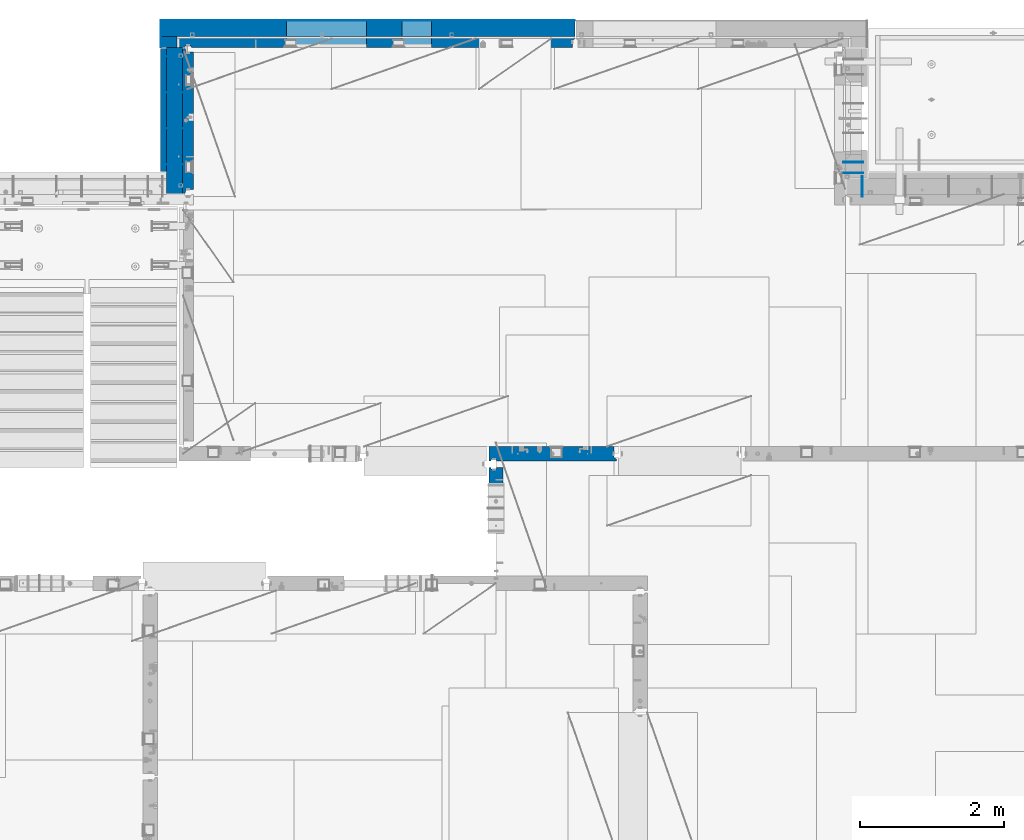
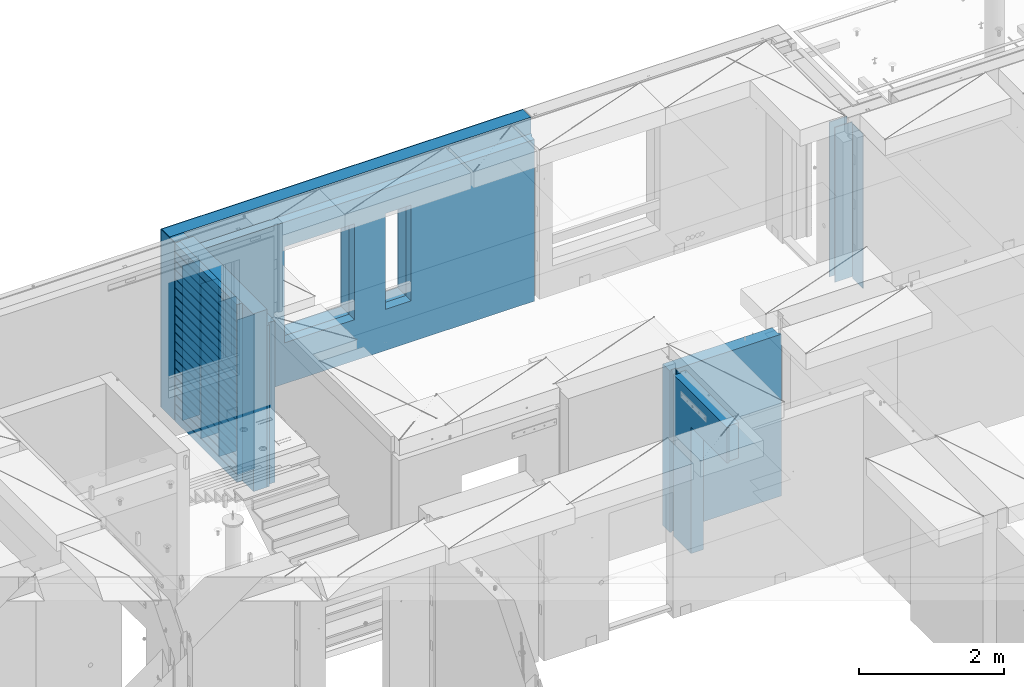
# One storey, part 231 of 341: 17 walls, 6 elements without a shape of their own.
"""IFC2X3 building model written with IfcOpenShell, lengths in millimetres."""

from ifc_helpers import new_model, si_unit, frame, origin_with_axes, place, context, subcontext, project, spatial, faceted_brep, material, type_object, element, aggregate, save


model = new_model("IFC2X3")

# Units and contexts
model_context = context("Model", 3, precision=1e-05, world=origin_with_axes())
body_context = subcontext(model_context, "Body", "Model", "MODEL_VIEW")
ifc_project = project(units=[si_unit("LENGTHUNIT", "METRE", prefix="MILLI"), si_unit("AREAUNIT", "SQUARE_METRE"), si_unit("VOLUMEUNIT", "CUBIC_METRE"), si_unit("MASSUNIT", "GRAM", prefix="KILO"), si_unit("TIMEUNIT", "SECOND"), si_unit("PLANEANGLEUNIT", "RADIAN"), si_unit("SOLIDANGLEUNIT", "STERADIAN"), si_unit("THERMODYNAMICTEMPERATUREUNIT", "DEGREE_CELSIUS"), si_unit("LUMINOUSINTENSITYUNIT", "LUMEN")], contexts=[model_context])

# Site, building, storey
site_placement = place(None, origin_with_axes())
site = spatial("IfcSite", under=ifc_project, at=site_placement, CompositionType="ELEMENT")
building_placement = place(site_placement, origin_with_axes())
building = spatial("IfcBuilding", under=site, at=building_placement, CompositionType="ELEMENT")
storey_placement = place(building_placement, origin_with_axes())
storey = spatial("IfcBuildingStorey", under=building, at=storey_placement, Name="5", CompositionType="ELEMENT", Elevation=0.0)

# Assembly, wall
assembly_1_placement = place(storey_placement, origin_with_axes())
assembly_1 = element("IfcElementAssembly", 1, at=assembly_1_placement, inside=storey, AssemblyPlace="NOTDEFINED", PredefinedType="REINFORCEMENT_UNIT")
ifc_material_1 = material(Name="Undefined")
wall_type_1 = type_object("IfcWallType", PredefinedType="NOTDEFINED")
wall_1_placement = place(assembly_1_placement, frame((31695.0, 20549.9951872276, 95115.0), z_axis=(0.0, 0.0, 1.0), x_axis=(0.0, 1.0, 0.0)))
wall_1 = element("IfcWall", 2, at=wall_1_placement, type_object=wall_type_1, material=ifc_material_1, Name="(PD)", context=body_context, shape_type="Brep", body=[
    faceted_brep([(0.0, 5.0, -1300.0), (0.0, 5.0, 1300.0), (280.0, 5.0, 1300.0), (280.0, 5.0, -1300.0), (0.0, -5.0, 1300.0), (280.0, -5.0, 1300.0), (0.0, -5.0, -1300.0), (280.0, -5.0, -1300.0)], [[[0, 1, 2, 3]], [[1, 4, 5, 2]], [[4, 6, 7, 5]], [[6, 0, 3, 7]], [[5, 7, 3, 2]], [[6, 4, 1, 0]]]),
])
aggregate(assembly_1, [wall_1])

# Assembly, walls
assembly_2_placement = place(storey_placement, origin_with_axes())
assembly_2 = element("IfcElementAssembly", 3, at=assembly_2_placement, inside=storey, AssemblyPlace="NOTDEFINED", PredefinedType="REINFORCEMENT_UNIT")
wall_2_placement = place(assembly_2_placement, frame((22290.0, 22495.0, 95110.0), z_axis=(0.0, 0.0, 1.0), x_axis=(-1.0, 3.00000001838171e-08, 0.0)))
wall_2 = element("IfcWall", 4, at=wall_2_placement, type_object=wall_type_1, material=ifc_material_1, Name="(PD)", context=body_context, shape_type="Brep", body=[
    faceted_brep([(0.0, 5.0, -1300.0), (0.0, 5.0, 1300.0), (280.0, 5.0, 1300.0), (280.0, 5.0, -1300.0), (0.0, -5.0, 1300.0), (280.0, -5.0, 1300.0), (0.0, -5.0, -1300.0), (280.0, -5.0, -1300.0)], [[[0, 1, 2, 3]], [[1, 4, 5, 2]], [[4, 6, 7, 5]], [[6, 0, 3, 7]], [[5, 7, 3, 2]], [[6, 4, 1, 0]]]),
])
wall_3_placement = place(assembly_2_placement, frame((22290.0, 21995.0, 95110.0), z_axis=(0.0, 0.0, 1.0), x_axis=(-1.0, 3.00000001838171e-08, 0.0)))
wall_3 = element("IfcWall", 5, at=wall_3_placement, type_object=wall_type_1, material=ifc_material_1, Name="(PD)", context=body_context, shape_type="Brep", body=[
    faceted_brep([(0.0, 5.0, -1300.0), (0.0, 5.0, 1300.0), (280.0, 5.0, 1300.0), (280.0, 5.0, -1300.0), (0.0, -5.0, 1300.0), (280.0, -5.0, 1300.0), (0.0, -5.0, -1300.0), (280.0, -5.0, -1300.0)], [[[0, 1, 2, 3]], [[1, 4, 5, 2]], [[4, 6, 7, 5]], [[6, 0, 3, 7]], [[5, 7, 3, 2]], [[6, 4, 1, 0]]]),
])
wall_4_placement = place(assembly_2_placement, frame((22290.0, 21495.0, 95110.0), z_axis=(0.0, 0.0, 1.0), x_axis=(-1.0, 3.00000001838171e-08, 0.0)))
wall_4 = element("IfcWall", 6, at=wall_4_placement, type_object=wall_type_1, material=ifc_material_1, Name="(PD)", context=body_context, shape_type="Brep", body=[
    faceted_brep([(0.0, 5.0, -1300.0), (0.0, 5.0, 1300.0), (280.0, 5.0, 1300.0), (280.0, 5.0, -1300.0), (0.0, -5.0, 1300.0), (280.0, -5.0, 1300.0), (0.0, -5.0, -1300.0), (280.0, -5.0, -1300.0)], [[[0, 1, 2, 3]], [[1, 4, 5, 2]], [[4, 6, 7, 5]], [[6, 0, 3, 7]], [[5, 7, 3, 2]], [[6, 4, 1, 0]]]),
])

assembly_3_placement = place(storey_placement, origin_with_axes())
assembly_3 = element("IfcElementAssembly", 7, at=assembly_3_placement, inside=storey, AssemblyPlace="NOTDEFINED", PredefinedType="REINFORCEMENT_UNIT")
wall_5_placement = place(assembly_3_placement, frame((31429.9951872276, 20875.0, 95115.0), z_axis=(0.0, 0.0, 1.0), x_axis=(1.0, 0.0, 0.0)))
wall_5 = element("IfcWall", 8, at=wall_5_placement, type_object=wall_type_1, material=ifc_material_1, Name="(PD)", context=body_context, shape_type="Brep", body=[
    faceted_brep([(0.0, 5.0, -1300.0), (0.0, 5.0, 1300.0), (280.0, 5.0, 1300.0), (280.0, 5.0, -1300.0), (0.0, -5.0, 1300.0), (280.0, -5.0, 1300.0), (0.0, -5.0, -1300.0), (280.0, -5.0, -1300.0)], [[[0, 1, 2, 3]], [[1, 4, 5, 2]], [[4, 6, 7, 5]], [[6, 0, 3, 7]], [[5, 7, 3, 2]], [[6, 4, 1, 0]]]),
])
wall_6_placement = place(assembly_3_placement, frame((31429.9951872276, 21025.0, 95115.0), z_axis=(0.0, 0.0, 1.0), x_axis=(1.0, 0.0, 0.0)))
wall_6 = element("IfcWall", 9, at=wall_6_placement, type_object=wall_type_1, material=ifc_material_1, Name="(PD)", context=body_context, shape_type="Brep", body=[
    faceted_brep([(0.0, 5.0, -1300.0), (0.0, 5.0, 1300.0), (280.0, 5.0, 1300.0), (280.0, 5.0, -1300.0), (0.0, -5.0, 1300.0), (280.0, -5.0, 1300.0), (0.0, -5.0, -1300.0), (280.0, -5.0, -1300.0)], [[[0, 1, 2, 3]], [[1, 4, 5, 2]], [[4, 6, 7, 5]], [[6, 0, 3, 7]], [[5, 7, 3, 2]], [[6, 4, 1, 0]]]),
])
aggregate(assembly_3, [wall_5, wall_6])

# Wall
wall_7_placement = place(assembly_2_placement, frame((22290.0, 20995.0, 95110.0), z_axis=(0.0, 0.0, 1.0), x_axis=(-1.0, 3.00000001838171e-08, 0.0)))
wall_7 = element("IfcWall", 10, at=wall_7_placement, type_object=wall_type_1, material=ifc_material_1, Name="(PD)", context=body_context, shape_type="Brep", body=[
    faceted_brep([(0.0, 5.0, -1300.0), (0.0, 5.0, 1300.0), (280.0, 5.0, 1300.0), (280.0, 5.0, -1300.0), (0.0, -5.0, 1300.0), (280.0, -5.0, 1300.0), (0.0, -5.0, -1300.0), (280.0, -5.0, -1300.0)], [[[0, 1, 2, 3]], [[1, 4, 5, 2]], [[4, 6, 7, 5]], [[6, 0, 3, 7]], [[5, 7, 3, 2]], [[6, 4, 1, 0]]]),
])

# Assembly, wall
assembly_4_placement = place(storey_placement, origin_with_axes())
assembly_4 = element("IfcElementAssembly", 11, at=assembly_4_placement, inside=storey, AssemblyPlace="NOTDEFINED", PredefinedType="REINFORCEMENT_UNIT")
ifc_material_2 = material(Name="CONCRETE/C25/30")
wall_type_2 = type_object("IfcWallType", PredefinedType="NOTDEFINED")
wall_8_placement = place(assembly_4_placement, frame((26510.0014364077, 16980.0, 95112.5), z_axis=(0.0, 0.0, 1.0), x_axis=(1.0, 0.0, 0.0)))
wall_8 = element("IfcWall", 12, at=wall_8_placement, type_object=wall_type_2, material=ifc_material_2, context=body_context, shape_type="Brep", body=[
    faceted_brep([(1739.99847412109, 100.0, 1357.5), (1739.99847412109, -57.0, 1357.5), (1739.99847412109, -57.0, -1357.5), (1739.99847412109, 100.0, -1357.5), (1769.99847412109, -70.0, 1357.5), (1769.99847412109, -70.0, -1357.5), (0.0, -100.0, -1357.5), (0.0, -100.0, 1357.5), (0.0, 100.0, 1357.5), (0.0, 100.0, -1357.5), (29.998563592264, -100.0, -1357.5), (29.998563592264, -100.0, 1357.5), (29.998563592264, -80.0008544921875, -1357.5), (29.998563592264, -80.0008544921875, 1357.5), (109.998563592264, -80.0008544921875, -1357.5), (109.998563592264, -80.0008544921875, 1357.5), (109.998563592264, -100.0, -1357.5), (109.998563592264, -100.0, 1357.5), (1769.99847412109, -100.0, -1357.5), (1769.99847412109, -100.0, 1357.5)], [[[0, 1, 2, 3]], [[4, 5, 2, 1]], [[6, 7, 8, 9]], [[7, 6, 10, 11]], [[11, 10, 12, 13]], [[13, 12, 14, 15]], [[15, 14, 16, 17]], [[18, 19, 17, 16]], [[0, 8, 7, 11, 13, 15, 17, 19, 4, 1]], [[9, 8, 0, 3]], [[18, 16, 14, 12, 10, 6, 9, 3, 2, 5]], [[19, 18, 5, 4]]]),
])
aggregate(assembly_4, [wall_8])

assembly_5_placement = place(storey_placement, origin_with_axes())
assembly_5 = element("IfcElementAssembly", 13, at=assembly_5_placement, inside=storey, AssemblyPlace="NOTDEFINED", PredefinedType="REINFORCEMENT_UNIT")
wall_9_placement = place(assembly_5_placement, frame((26609.9991475894, 15280.0004107749, 95112.5), z_axis=(0.0, 0.0, 1.0), x_axis=(0.0, 1.0, 0.0)))
wall_9 = element("IfcWall", 14, at=wall_9_placement, type_object=wall_type_2, material=ifc_material_2, context=body_context, shape_type="Brep", body=[
    faceted_brep([(1509.99949975397, 70.0, 1357.5), (1489.99949975397, 70.0, 1357.5), (1489.99949975397, 70.0, -1357.5), (1509.99949975397, 70.0, -1357.5), (1489.99949975397, -10.0, 1357.5), (1489.99949975397, -10.0, -1357.5), (1509.99949975397, -10.0, 1357.5), (1509.99949975397, -10.0, -1357.5), (29.9995892251427, 70.0, 1357.5), (29.9995892251427, 70.0, 762.5), (59.9995892251427, 57.0, 762.5), (59.9995892251427, 57.0, 1357.5), (29.9995892251427, 100.0, 1357.5), (29.9995892251427, 100.0, 762.5), (1509.99949975397, 100.0, 1357.5), (1509.99949975397, 100.0, -1357.5), (1019.99979369292, 100.0, -1357.5), (1019.99979369292, 100.0, 762.5), (1019.99979369292, -100.0, 762.5), (1019.99979369292, -100.0, -1357.5), (59.9995892251427, -100.0, 762.5), (59.9995892251427, -100.0, 1357.5), (1509.99949975397, -100.0, -1357.5), (1509.99949975397, -100.0, 1357.5)], [[[0, 1, 2, 3]], [[4, 5, 2, 1]], [[6, 7, 5, 4]], [[8, 9, 10, 11]], [[12, 13, 9, 8]], [[12, 14, 15, 16, 17, 13]], [[18, 17, 16, 19]], [[9, 13, 17, 18, 20, 10]], [[21, 11, 10, 20]], [[18, 19, 22, 23, 21, 20]], [[1, 0, 14, 12, 8, 11, 21, 23, 6, 4]], [[15, 14, 0, 3]], [[22, 19, 16, 15, 3, 2, 5, 7]], [[23, 22, 7, 6]]]),
])
aggregate(assembly_5, [wall_9])

# Wall
ifc_material_3 = material(Name="COS5gt")
wall_type_3 = type_object("IfcWallType", PredefinedType="NOTDEFINED")
wall_10_placement = place(assembly_2_placement, frame((22150.0, 20595.0, 95247.5), z_axis=(0.0, 0.0, 1.0), x_axis=(0.0, 1.0, 0.0)))
wall_10 = element("IfcWall", 15, at=wall_10_placement, type_object=wall_type_3, material=ifc_material_3, context=body_context, shape_type="Brep", body=[
    faceted_brep([(0.0, 110.0, -1492.5), (0.0, 110.0, 1492.5), (2025.0, 110.0, 1492.5), (2025.0, 110.0, -1492.5), (0.0, -110.0, 1492.5), (2025.0, -110.0, 1492.5), (0.0, -110.0, -1492.5), (2025.0, -110.0, -1492.5)], [[[0, 1, 2, 3]], [[1, 4, 5, 2]], [[4, 6, 7, 5]], [[6, 0, 3, 7]], [[5, 7, 3, 2]], [[6, 4, 1, 0]]]),
])

# Assembly, walls
assembly_6_placement = place(storey_placement, origin_with_axes())
assembly_6 = element("IfcElementAssembly", 16, at=assembly_6_placement, inside=storey, AssemblyPlace="NOTDEFINED", PredefinedType="REINFORCEMENT_UNIT")
ifc_material_4 = material()
wall_11_placement = place(assembly_6_placement, frame((22075.0, 22620.0, 95247.5), z_axis=(0.0, 0.0, 1.0), x_axis=(0.0, 1.0, 0.0)))
wall_11 = element("IfcWall", 17, at=wall_11_placement, type_object=wall_type_3, material=ifc_material_4, context=body_context, shape_type="Brep", body=[
    faceted_brep([(0.0, 110.0, -1492.5), (0.0, 110.0, 1492.5), (150.0, 110.0, 1492.5), (150.0, 110.0, -1492.5), (0.0, -110.0, 1492.5), (150.0, -110.0, 1492.5), (0.0, -110.0, -1492.5), (150.0, -110.0, -1492.5)], [[[0, 1, 2, 3]], [[1, 4, 5, 2]], [[4, 6, 7, 5]], [[6, 0, 3, 7]], [[5, 7, 3, 2]], [[6, 4, 1, 0]]]),
])
wall_12_placement = place(assembly_6_placement, frame((22260.0, 22880.0, 95247.5), z_axis=(0.0, 0.0, 1.0), x_axis=(1.0, 0.0, 0.0)))
wall_12 = element("IfcWall", 18, at=wall_12_placement, type_object=wall_type_3, material=ifc_material_4, context=body_context, shape_type="Brep", body=[
    faceted_brep([(-295.0, 110.0, 1492.5), (-295.0, -110.0, 1492.5), (5445.0, -110.0, 1492.5), (5445.0, 110.0, 1492.5), (-295.0, -110.0, -1492.5), (-295.0, 110.0, -1492.5), (5445.0, 110.0, -1492.5), (5445.0, -110.0, -1492.5), (3044.99635379813, 110.0, -802.5), (3454.99635379813, 110.0, -802.5), (3454.99635379813, 110.0, 807.5), (3044.99635379813, 110.0, 807.5), (1444.99910133321, 110.0, -802.5), (2554.99910133321, 110.0, -802.5), (2554.99910133321, 110.0, 807.5), (1444.99910133321, 110.0, 807.5), (1444.99910133321, -110.0, -802.5), (2554.99910133321, -110.0, -802.5), (1444.99910133321, -110.0, 807.5), (2554.99910133321, -110.0, 807.5), (3044.99635379813, -110.0, -802.5), (3044.99635379813, -110.0, 807.5), (3454.99635379813, -110.0, 807.5), (3454.99635379813, -110.0, -802.5)], [[[0, 1, 2, 3]], [[4, 1, 0, 5]], [[4, 5, 6, 7]], [[2, 7, 6, 3]], [[5, 0, 3, 6], [8, 9, 10, 11], [12, 13, 14, 15]], [[12, 16, 17, 13]], [[15, 18, 16, 12]], [[14, 19, 18, 15]], [[13, 17, 19, 14]], [[1, 4, 7, 2], [20, 21, 22, 23], [16, 18, 19, 17]], [[10, 22, 21, 11]], [[9, 23, 22, 10]], [[8, 20, 23, 9]], [[11, 21, 20, 8]]]),
])

# Wall
ifc_material_5 = material(Name="CONCRETE/C30/37")
wall_type_4 = type_object("IfcWallType", PredefinedType="NOTDEFINED")
wall_13_placement = place(assembly_2_placement, frame((21997.5, 20900.0, 95247.5), z_axis=(0.0, 0.0, 1.0), x_axis=(0.0, 1.0, 0.0)))
wall_13 = element("IfcWall", 19, at=wall_13_placement, type_object=wall_type_4, material=ifc_material_5, context=body_context, shape_type="Brep", body=[
    faceted_brep([(1705.0, 42.5, -1357.0), (0.0, 42.5, -1357.00000005524), (0.0, 32.4999992507037, -1355.00000000074), (1705.0, 32.5, -1355.0), (1705.0, 32.5, -1345.0), (0.0, 32.4999991127006, -1344.99999959956), (0.0, 42.5, -1343.00000011075), (1705.0, 42.5, -1343.0), (0.0, -42.5, -1492.5), (0.0, 42.5, -1492.5), (1705.0, 42.5, -1492.5), (1705.0, -42.5, -1492.5), (0.0, -42.5, 1492.5), (1705.0, -42.5, 1492.5), (0.0, 42.5, 1492.5), (1705.0, 42.5, 1492.5), (1705.0, 42.5, 1357.0), (0.0, 42.5, 1356.99999988925), (1705.0, 32.5, 1355.0), (-3.63797880709171e-12, 32.4999991127006, 1355.00000040044), (1705.0, 32.5, 1345.0), (-3.63797880709171e-12, 32.4999992507037, 1344.99999999926), (1705.0, 42.5, 1343.0), (0.0, 42.5, 1342.99999994476), (1705.0, 42.5, 1207.0), (0.0, 42.5, 1206.99999988925), (1705.0, 32.5, 1205.0), (0.0, 32.4999991127006, 1205.00000040044), (1705.0, 32.5, 1195.0), (0.0, 32.4999992507037, 1194.99999999926), (1705.0, 42.5, 1193.0), (0.0, 42.5, 1192.99999994476), (1705.0, 42.5, 1057.0), (0.0, 42.5, 1056.99999988925), (1705.0, 32.5, 1055.0), (0.0, 32.4999991127006, 1055.00000040044), (1705.0, 32.5, 1045.0), (0.0, 32.4999992507037, 1044.99999999926), (1705.0, 42.5, 1043.0), (0.0, 42.5, 1042.99999994476), (1705.0, 42.5, 907.0), (0.0, 42.5, 906.999999889245), (1705.0, 32.5, 905.0), (0.0, 32.4999991127006, 905.00000040044), (1705.0, 32.5, 895.0), (0.0, 32.4999992507037, 894.999999999258), (1705.0, 42.5, 893.0), (0.0, 42.5, 892.999999944761), (1705.0, 42.5, 757.0), (0.0, 42.5, 756.999999889245), (1705.0, 32.5, 755.0), (0.0, 32.4999991127006, 755.00000040044), (1705.0, 32.5, 745.0), (0.0, 32.4999992507037, 744.999999999258), (1705.0, 42.5, 743.0), (0.0, 42.5, 742.999999944761), (1705.0, 42.5, 607.0), (0.0, 42.5, 606.999999889245), (1705.0, 32.5, 605.0), (3.63797880709171e-12, 32.4999991127006, 605.00000040044), (1705.0, 32.5, 595.0), (3.63797880709171e-12, 32.4999992507037, 594.999999999258), (1705.0, 42.5, 593.0), (0.0, 42.5, 592.999999944761), (1705.0, 42.5, 457.0), (0.0, 42.5, 456.999999889245), (1705.0, 32.5, 455.0), (0.0, 32.4999991127006, 455.00000040044), (1705.0, 32.5, 445.0), (0.0, 32.4999992507037, 444.999999999258), (1705.0, 42.5, 443.0), (0.0, 42.5, 442.999999944761), (1705.0, 42.5, 307.0), (0.0, 42.5, 306.999999889245), (1705.0, 32.5, 305.0), (-3.63797880709171e-12, 32.4999991127006, 305.00000040044), (1705.0, 32.5, 295.0), (-3.63797880709171e-12, 32.4999992507037, 294.999999999258), (1705.0, 42.5, 293.0), (0.0, 42.5, 292.999999944761), (1705.0, 42.5, 157.0), (0.0, 42.5, 156.999999889245), (1705.0, 32.5, 155.0), (-3.63797880709171e-12, 32.4999991127006, 155.00000040044), (1705.0, 32.5, 145.0), (-3.63797880709171e-12, 32.4999992507037, 144.999999999258), (1705.0, 42.5, 143.0), (0.0, 42.5, 142.999999944761), (1705.0, 42.5, 7.0), (0.0, 42.5, 6.99999988924537), (1705.0, 32.5, 5.0), (0.0, 32.4999991127006, 5.0000004004396), (1705.0, 32.5, -5.0), (0.0, 32.4999992507037, -5.00000000074215), (1705.0, 42.5, -7.0), (0.0, 42.5, -7.00000005523907), (1705.0, 42.5, -143.0), (0.0, 42.5, -143.000000110755), (1705.0, 32.5, -145.0), (3.63797880709171e-12, 32.4999991127006, -144.99999959956), (1705.0, 32.5, -155.0), (3.63797880709171e-12, 32.4999992507037, -155.000000000742), (1705.0, 42.5, -157.0), (0.0, 42.5, -157.000000055239), (1705.0, 42.5, -293.0), (0.0, 42.5, -293.000000110755), (1705.0, 32.5, -295.0), (0.0, 32.4999991127006, -294.99999959956), (1705.0, 32.5, -305.0), (0.0, 32.4999992507037, -305.000000000742), (1705.0, 42.5, -307.0), (0.0, 42.5, -307.000000055239), (1705.0, 42.5, -443.0), (0.0, 42.5, -443.000000110755), (1705.0, 32.5, -445.0), (0.0, 32.4999991127006, -444.99999959956), (1705.0, 32.5, -455.0), (0.0, 32.4999992507037, -455.000000000742), (1705.0, 42.5, -457.0), (0.0, 42.5, -457.000000055239), (1705.0, 42.5, -593.0), (0.0, 42.5, -593.000000110755), (1705.0, 32.5, -595.0), (3.63797880709171e-12, 32.4999991127006, -594.99999959956), (1705.0, 32.5, -605.0), (3.63797880709171e-12, 32.4999992507037, -605.000000000742), (1705.0, 42.5, -607.0), (0.0, 42.5, -607.000000055239), (1705.0, 42.5, -743.0), (0.0, 42.5, -743.000000110755), (1705.0, 32.5, -745.0), (0.0, 32.4999991127006, -744.99999959956), (1705.0, 32.5, -755.0), (0.0, 32.4999992507037, -755.000000000742), (1705.0, 42.5, -757.0), (0.0, 42.5, -757.000000055239), (1705.0, 42.5, -893.0), (0.0, 42.5, -893.000000110755), (1705.0, 32.5, -895.0), (0.0, 32.4999991127006, -894.99999959956), (1705.0, 32.5, -905.0), (0.0, 32.4999992507037, -905.000000000742), (1705.0, 42.5, -907.0), (0.0, 42.5, -907.000000055239), (1705.0, 42.5, -1043.0), (0.0, 42.5, -1043.00000011075), (1705.0, 32.5, -1045.0), (0.0, 32.4999991127006, -1044.99999959956), (1705.0, 32.5, -1055.0), (0.0, 32.4999992507037, -1055.00000000074), (1705.0, 42.5, -1057.0), (0.0, 42.5, -1057.00000005524), (1705.0, 42.5, -1193.0), (0.0, 42.5, -1193.00000011075), (1705.0, 32.5, -1195.0), (0.0, 32.4999991127006, -1194.99999959956), (1705.0, 32.5, -1205.0), (0.0, 32.4999992507037, -1205.00000000074), (1705.0, 42.5, -1207.0), (0.0, 42.5, -1207.00000005524)], [[[0, 1, 2, 3]], [[4, 5, 6, 7]], [[3, 2, 5, 4]], [[8, 9, 10, 11]], [[12, 8, 11, 13]], [[14, 12, 13, 15]], [[14, 15, 16, 17]], [[18, 19, 17, 16]], [[20, 21, 19, 18]], [[22, 23, 21, 20]], [[24, 25, 23, 22]], [[26, 27, 25, 24]], [[28, 29, 27, 26]], [[30, 31, 29, 28]], [[32, 33, 31, 30]], [[34, 35, 33, 32]], [[36, 37, 35, 34]], [[38, 39, 37, 36]], [[40, 41, 39, 38]], [[42, 43, 41, 40]], [[44, 45, 43, 42]], [[46, 47, 45, 44]], [[48, 49, 47, 46]], [[50, 51, 49, 48]], [[52, 53, 51, 50]], [[54, 55, 53, 52]], [[56, 57, 55, 54]], [[58, 59, 57, 56]], [[60, 61, 59, 58]], [[62, 63, 61, 60]], [[64, 65, 63, 62]], [[66, 67, 65, 64]], [[68, 69, 67, 66]], [[70, 71, 69, 68]], [[72, 73, 71, 70]], [[74, 75, 73, 72]], [[76, 77, 75, 74]], [[78, 79, 77, 76]], [[80, 81, 79, 78]], [[82, 83, 81, 80]], [[84, 85, 83, 82]], [[86, 87, 85, 84]], [[88, 89, 87, 86]], [[90, 91, 89, 88]], [[92, 93, 91, 90]], [[94, 95, 93, 92]], [[96, 97, 95, 94]], [[98, 99, 97, 96]], [[100, 101, 99, 98]], [[102, 103, 101, 100]], [[104, 105, 103, 102]], [[106, 107, 105, 104]], [[108, 109, 107, 106]], [[110, 111, 109, 108]], [[112, 113, 111, 110]], [[114, 115, 113, 112]], [[116, 117, 115, 114]], [[118, 119, 117, 116]], [[120, 121, 119, 118]], [[122, 123, 121, 120]], [[124, 125, 123, 122]], [[126, 127, 125, 124]], [[128, 129, 127, 126]], [[130, 131, 129, 128]], [[132, 133, 131, 130]], [[134, 135, 133, 132]], [[136, 137, 135, 134]], [[138, 139, 137, 136]], [[140, 141, 139, 138]], [[142, 143, 141, 140]], [[144, 145, 143, 142]], [[146, 147, 145, 144]], [[148, 149, 147, 146]], [[150, 151, 149, 148]], [[152, 153, 151, 150]], [[154, 155, 153, 152]], [[156, 157, 155, 154]], [[158, 159, 157, 156]], [[7, 6, 159, 158]], [[21, 23, 25, 27, 29, 31, 33, 35, 37, 39, 41, 43, 45, 47, 49, 51, 53, 55, 57, 59, 61, 63, 65, 67, 69, 71, 73, 75, 77, 79, 81, 83, 85, 87, 89, 91, 93, 95, 97, 99, 101, 103, 105, 107, 109, 111, 113, 115, 117, 119, 121, 123, 125, 127, 129, 131, 133, 135, 137, 139, 141, 143, 145, 147, 149, 151, 153, 155, 157, 159, 6, 5, 2, 1, 9, 8, 12, 14, 17, 19]], [[10, 9, 1, 0]], [[15, 13, 11, 10, 0, 3, 4, 7, 158, 156, 154, 152, 150, 148, 146, 144, 142, 140, 138, 136, 134, 132, 130, 128, 126, 124, 122, 120, 118, 116, 114, 112, 110, 108, 106, 104, 102, 100, 98, 96, 94, 92, 90, 88, 86, 84, 82, 80, 78, 76, 74, 72, 70, 68, 66, 64, 62, 60, 58, 56, 54, 52, 50, 48, 46, 44, 42, 40, 38, 36, 34, 32, 30, 28, 26, 24, 22, 20, 18, 16]]]),
])

wall_type_5 = type_object("IfcWallType", PredefinedType="NOTDEFINED")
wall_14_placement = place(assembly_6_placement, frame((22192.5, 22695.0, 95112.5), z_axis=(0.0, 0.0, 1.0), x_axis=(1.0, 0.0, 0.0)))
wall_14 = element("IfcWall", 20, at=wall_14_placement, type_object=wall_type_5, material=ifc_material_2, context=body_context, shape_type="Brep", body=[
    faceted_brep([(3112.49635379813, 75.0, 942.5), (3112.49635379813, -75.0000009061441, 942.5), (3112.49635379813, -75.0000002303786, -667.5), (3112.49635379813, 75.0, -667.5), (3522.49635379813, -75.0000001420558, -667.5), (3522.49635379813, 75.0, -667.5), (3522.49635379813, -75.0000008178213, 942.5), (3522.49635379813, 75.0, 942.5), (5482.5, -75.0, 1357.5), (5482.5, -75.0, -1357.5), (5482.5, 24.9999980926514, -1357.5), (5482.5, 24.9999980926514, 1357.5), (5512.5, 45.0, 1357.5), (5512.5, 75.0, 1357.5), (0.0, 75.0, 1357.5), (0.0, -75.0, 1357.5), (92.5, -75.0, 1357.5), (102.5, -55.0000022791319, 1357.5), (182.5, -55.0000022791319, 1357.5), (192.5, -75.0000022791319, 1357.5), (0.0, -75.0, -1357.5), (0.0, 75.0, -1357.5), (92.5, -75.0, -1357.5), (102.5, -55.0000022791319, -1357.5), (182.5, -55.0000022791319, -1357.5), (192.5, -75.0, -1357.5), (5512.5, 75.0, -1357.5), (5512.5, 45.0, -1357.5), (1512.49910133321, 75.0, -667.5), (2622.49910133321, 75.0, -667.5), (2622.49910133321, 75.0, 942.5), (1512.49910133321, 75.0, 942.5), (1512.49910133321, -75.000000575048, -667.5), (2622.49910133321, -75.000000335931, -667.5), (1512.49910133321, -75.0000012508135, 942.5), (2622.49910133321, -75.0000010116964, 942.5)], [[[0, 1, 2, 3]], [[3, 2, 4, 5]], [[5, 4, 6, 7]], [[7, 6, 1, 0]], [[8, 9, 10, 11]], [[8, 11, 12, 13, 14, 15, 16, 17, 18, 19]], [[20, 15, 14, 21]], [[15, 20, 22, 16]], [[16, 22, 23, 17]], [[17, 23, 24, 18]], [[19, 18, 24, 25]], [[23, 22, 20, 21, 26, 27, 10, 9, 25, 24]], [[12, 11, 10, 27]], [[26, 13, 12, 27]], [[21, 14, 13, 26], [3, 5, 7, 0], [28, 29, 30, 31]], [[28, 32, 33, 29]], [[31, 34, 32, 28]], [[30, 35, 34, 31]], [[29, 33, 35, 30]], [[9, 8, 19, 25], [2, 1, 6, 4], [32, 34, 35, 33]]]),
])

wall_15_placement = place(assembly_2_placement, frame((22335.0, 20595.0, 95112.5), z_axis=(0.0, 0.0, 1.0), x_axis=(0.0, 1.0, 0.0)))
wall_15 = element("IfcWall", 21, at=wall_15_placement, type_object=wall_type_5, material=ifc_material_2, context=body_context, shape_type="Brep", body=[
    faceted_brep([(0.0, 40.0, 1357.5), (0.0, 40.0, -1357.5), (50.0, 27.0, -1357.5), (50.0, 27.0, 1357.5), (50.0, -75.0, 1357.5), (50.0, -75.0, -1357.5), (0.0, 75.0, -1357.5), (0.0, 75.0, 1357.5), (2009.99999772087, 75.0, 1357.5), (2009.99999772087, 75.0, -1357.5), (2009.99999772087, 40.0, 1357.5), (2009.99999772087, 40.0, -1357.5), (1959.99999772087, 27.0, 1357.5), (1959.99999772087, 27.0, -1357.5), (1959.99999772087, -75.0, 1357.5), (1959.99999772087, -75.0, -1357.5)], [[[0, 1, 2, 3]], [[4, 3, 2, 5]], [[6, 7, 8, 9]], [[9, 8, 10, 11]], [[12, 13, 11, 10]], [[14, 15, 13, 12]], [[15, 14, 4, 5]], [[1, 6, 9, 11, 13, 15, 5, 2]], [[7, 6, 1, 0]], [[14, 12, 10, 8, 7, 0, 3, 4]]]),
])

aggregate(assembly_2, [wall_10, wall_2, wall_3, wall_4, wall_7, wall_13, wall_15])

wall_type_6 = type_object("IfcWallType", PredefinedType="NOTDEFINED")
wall_16_placement = place(assembly_6_placement, frame((21960.0001313636, 22620.0, 95247.5), z_axis=(0.0, 0.0, 1.0), x_axis=(0.0, 1.0, 0.0)))
wall_16 = element("IfcWall", 22, at=wall_16_placement, type_object=wall_type_6, material=ifc_material_5, context=body_context, shape_type="Brep", body=[
    faceted_brep([(0.0, 5.0, -1492.5), (0.0, 5.0, 1492.5), (370.0, 5.0, 1492.5), (370.0, 5.0, -1492.5), (0.0, -5.0, 1492.5), (370.0, -5.0, 1492.5), (0.0, -5.0, -1492.5), (370.0, -5.0, -1492.5)], [[[0, 1, 2, 3]], [[1, 4, 5, 2]], [[4, 6, 7, 5]], [[6, 0, 3, 7]], [[5, 7, 3, 2]], [[6, 4, 1, 0]]]),
])

wall_17_placement = place(assembly_6_placement, frame((22260.0, 22995.0, 95247.5), z_axis=(0.0, 0.0, 1.0), x_axis=(1.0, 0.0, 0.0)))
wall_17 = element("IfcWall", 23, at=wall_17_placement, type_object=wall_type_6, material=ifc_material_5, context=body_context, shape_type="Brep", body=[
    faceted_brep([(-305.0, 5.0, 1492.5), (-305.0, -5.0, 1492.5), (5445.0, -5.0, 1492.5), (5445.0, 5.0, 1492.5), (-305.0, -5.0, -1492.5), (-305.0, 5.0, -1492.5), (5445.0, 5.0, -1492.5), (5445.0, -5.0, -1492.5), (3044.99635379813, 5.0, -802.5), (3454.99635379813, 5.0, -802.5), (3454.99635379813, 5.0, 807.5), (3044.99635379813, 5.0, 807.5), (1444.99910133321, 5.0, -802.5), (2554.99910133321, 5.0, -802.5), (2554.99910133321, 5.0, 807.5), (1444.99910133321, 5.0, 807.5), (1444.99910133321, -5.0, -802.5), (2554.99910133321, -5.0, -802.5), (1444.99910133321, -5.0, 807.5), (2554.99910133321, -5.0, 807.5), (3044.99635379813, -5.0, -802.5), (3044.99635379813, -5.0, 807.5), (3454.99635379813, -5.0, 807.5), (3454.99635379813, -5.0, -802.5)], [[[0, 1, 2, 3]], [[4, 1, 0, 5]], [[4, 5, 6, 7]], [[2, 7, 6, 3]], [[5, 0, 3, 6], [8, 9, 10, 11], [12, 13, 14, 15]], [[12, 16, 17, 13]], [[15, 18, 16, 12]], [[14, 19, 18, 15]], [[13, 17, 19, 14]], [[1, 4, 7, 2], [20, 21, 22, 23], [16, 18, 19, 17]], [[10, 22, 21, 11]], [[9, 23, 22, 10]], [[8, 20, 23, 9]], [[11, 21, 20, 8]]]),
])

aggregate(assembly_6, [wall_16, wall_11, wall_12, wall_17, wall_14])

save(model, "model.ifc")
